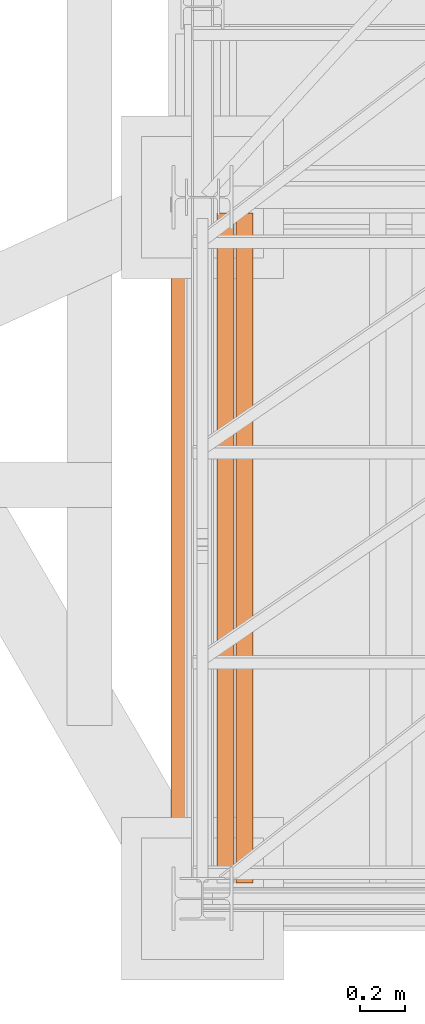
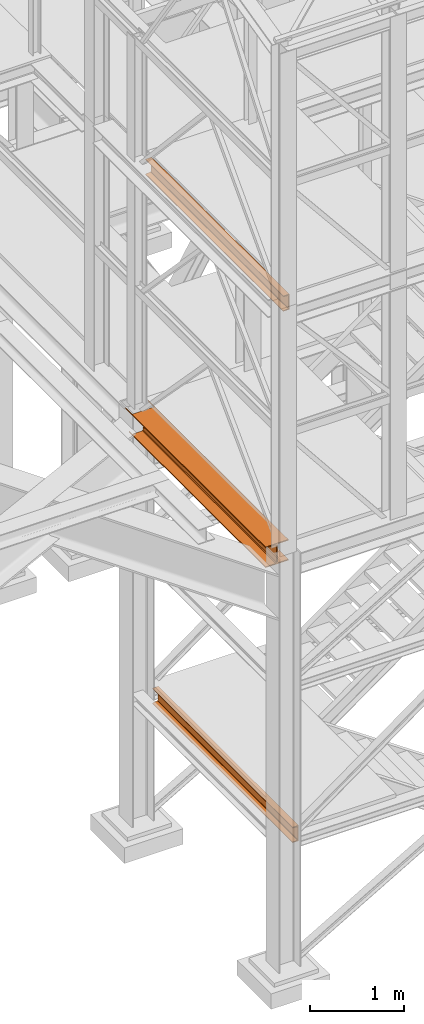
# One storey, part 5 of 208: 3 proxies.
"""IFC2X3 building model written with IfcOpenShell, lengths in millimetres."""

from ifc_helpers import new_model, entity, si_unit, converted_unit, frame, origin, origin_with_axes, place, context, subcontext, project, spatial, faceted_brep, element, save


model = new_model("IFC2X3")

# Units and contexts
model_context = context("Model", 3, precision=1e-05, world=origin())
plan_context = context("Plan", 3, precision=1e-05, world=origin())
body_context = subcontext(model_context, "Body", "Model", "MODEL_VIEW")
ifc_project = project(units=[si_unit("LENGTHUNIT", "METRE", prefix="MILLI"), converted_unit("PLANEANGLEUNIT", "DEGREE", entity("IfcPlaneAngleMeasure", 0.0174532925199433), si_unit("PLANEANGLEUNIT", "RADIAN"), dimensions=[0, 0, 0, 0, 0, 0, 0]), si_unit("AREAUNIT", "SQUARE_METRE"), si_unit("VOLUMEUNIT", "CUBIC_METRE")], contexts=[model_context, plan_context])

# Building, storey
building_placement = place(None, origin())
building = spatial("IfcBuilding", under=ifc_project, at=building_placement, CompositionType="COMPLEX")
storey_placement = place(building_placement, origin_with_axes())
storey = spatial("IfcBuildingStorey", under=building, at=storey_placement, Name="Geschoss", CompositionType="ELEMENT")

# Proxies
proxy_1_placement = place(storey_placement, frame((1058.254967932617, -25032.57438972183, 5014.98999463558), z_axis=(0.0, 0.0, 1.0), x_axis=(1.0, 0.0, 0.0)))
element("IfcBuildingElementProxy", 1, at=proxy_1_placement, inside=storey, context=body_context, shape_type="Brep", body=[
    faceted_brep([(280.0100011920947, 2970.009999403952, 270.0100107288363), (274.9198562138097, 2970.009999403952, 270.0100107288363), (274.9198562138097, 2970.009999403952, 257.0100141859057), (280.0100011920947, 2970.009999403952, 257.0100141859057), (274.9198562138097, 2970.009999403952, 13.00999654293082), (274.9198562138097, 2970.009999403952, 0.01000000000021828), (280.0100011920947, 2970.009999403952, 0.01000000000021828), (280.0100011920947, 2970.009999403952, 13.00999654293082), (4.91984548497453, 2970.009999403952, 257.0100141859057), (4.91984548497453, 2970.009999403952, 270.0100107288363), (0.009999999999990905, 2970.009999403952, 270.0100107288363), (0.009999999999990905, 2970.009999403952, 257.0100141859057), (0.009999999999990905, 2970.009999403952, 270.0100107288363), (4.91984548497453, 2970.009999403952, 270.0100107288363), (4.91984548497453, 2830.009998807902, 270.0100107288354), (274.9198562138097, 2830.009998807902, 270.0100107288354), (274.9198562138097, 2970.009999403952, 270.0100107288363), (280.0100011920947, 2970.009999403952, 270.0100107288363), (280.0100011920947, 0.00999999999839929, 270.0100107288354), (0.009999999999990905, 0.00999999999839929, 270.0100107288354), (0.009999999999990905, 2970.009999403952, 257.0100141859057), (0.009999999999990905, 2970.009999403952, 270.0100107288363), (0.009999999999990905, 0.00999999999839929, 270.0100107288354), (0.009999999999990905, 0.00999999999839929, 257.0100141859057), (4.91984548497453, 2970.009999403952, 257.0100141859057), (0.009999999999990905, 2970.009999403952, 257.0100141859057), (0.009999999999990905, 0.00999999999839929, 257.0100141859057), (112.0099997317782, 0.00999999999839929, 257.0100141859057), (112.0099997317791, 2830.009998807902, 257.0100141859057), (4.91984548497453, 2830.009998807902, 257.0100141859057), (112.0099997317791, 2830.009998807902, 257.0100141859057), (112.0099997317782, 0.00999999999839929, 257.0100141859057), (124.4310805743924, 0.00999999999839929, 254.5239491558077), (124.4310805743933, 2830.009998807902, 254.5239491558077), (124.4310805743933, 2830.009998807902, 254.5239491558077), (124.4310805743924, 0.00999999999839929, 254.5239491558077), (133.5239363072813, 0.00999999999839929, 245.4310892319681), (133.5239363072803, 2830.009998807902, 245.4310892319681), (133.5239363072803, 2830.009998807902, 245.4310892319681), (133.5239363072813, 0.00999999999839929, 245.4310892319681), (136.0100004060566, 0.00999999999839929, 233.0100102519991), (136.0100004060566, 2830.009998807902, 233.0100102519991), (136.0100004060566, 2830.009998807902, 233.0100102519991), (136.0100004060566, 0.00999999999839929, 233.0100102519991), (136.0100004060566, 0.00999999999839929, 37.01000047683738), (136.0100004060566, 2830.009998807902, 37.01000047683738), (136.0100004060566, 2830.009998807902, 55.01001072883628), (136.0100004060557, 2803.43875191277, 55.01001072883719), (136.0100004060566, 2803.43875191277, 80.01001072883628), (136.0100004060557, 2830.009998807902, 80.01001072883628), (136.0100004060566, 2830.009998807902, 37.01000047683738), (136.0100004060566, 0.00999999999839929, 37.01000047683738), (133.5239363072813, 0.00999999999839929, 24.58892149686835), (133.5239363072813, 2830.009998807902, 24.58892149686835), (133.5239363072813, 2830.009998807902, 24.58892149686835), (133.5239363072813, 0.00999999999839929, 24.58892149686835), (124.4310805743924, 0.00999999999839929, 15.49606157302878), (124.4310805743924, 2830.009998807902, 15.49606157302878), (124.4310805743924, 2830.009998807902, 15.49606157302878), (124.4310805743924, 0.00999999999839929, 15.49606157302878), (112.0099997317791, 0.00999999999839929, 13.00999654293082), (112.0099997317791, 2830.009998807902, 13.00999654293082), (4.91984548497453, 2830.009998807902, 13.00999654293173), (112.0099997317791, 2830.009998807902, 13.00999654293082), (112.0099997317791, 0.00999999999839929, 13.00999654293082), (0.009999999999990905, 0.00999999999839929, 13.00999654293082), (0.009999999999990905, 2890.498682317633, 13.00999654293082), (4.919845484972711, 2893.34256245166, 13.00999654293082), (0.009999999999990905, 2890.498682317633, 0.01000000000021828), (0.009999999999990905, 2890.498682317633, 13.00999654293082), (0.009999999999990905, 0.00999999999839929, 13.00999654293082), (0.009999999999990905, 0.00999999999839929, 0.01000000000021828), (280.0100011920947, 2970.009999403952, 0.01000000000021828), (274.9198562138097, 2970.009999403952, 0.01000000000021828), (274.9198562138106, 2830.009998807902, 0.01000000000112777), (4.91984548497453, 2830.009998807902, 0.01000000000112777), (4.919845484973621, 2893.342562451664, 0.01000000000021828), (0.009999999999990905, 2890.498682317633, 0.01000000000021828), (0.009999999999990905, 0.00999999999839929, 0.01000000000021828), (280.0100011920956, 0.00999999999839929, 0.01000000000021828), (280.0100011920947, 2970.009999403952, 13.00999654293082), (280.0100011920947, 2970.009999403952, 0.01000000000021828), (280.0100011920956, 0.00999999999839929, 0.01000000000021828), (280.0100011920938, 0.00999999999839929, 13.00999654293082), (274.9198562138097, 2970.009999403952, 13.00999654293082), (280.0100011920947, 2970.009999403952, 13.00999654293082), (280.0100011920938, 0.00999999999839929, 13.00999654293082), (168.0100014603138, 0.00999999999839929, 13.00999654293082), (168.0100014603138, 2830.009998807902, 13.00999654293082), (274.9198562138097, 2830.009998807902, 13.00999654293082), (168.0100014603138, 2830.009998807902, 13.00999654293082), (168.0100014603138, 0.00999999999839929, 13.00999654293082), (155.5889206176987, 0.00999999999839929, 15.49606157302878), (155.5889206176996, 2830.009998807902, 15.49606157302878), (155.5889206176996, 2830.009998807902, 15.49606157302878), (155.5889206176987, 0.00999999999839929, 15.49606157302878), (146.4960648848116, 0.00999999999839929, 24.58892149686835), (146.4960648848116, 2830.009998807902, 24.58892149686835), (146.4960648848116, 2830.009998807902, 24.58892149686835), (146.4960648848116, 0.00999999999839929, 24.58892149686835), (144.0100007860362, 0.00999999999839929, 37.01000047683647), (144.0100007860362, 2830.009998807902, 37.01000047683738), (144.0100007860362, 2830.009998807902, 37.01000047683738), (144.0100007860362, 0.00999999999839929, 37.01000047683647), (144.0100007860372, 0.00999999999839929, 233.0100102519964), (144.0100007860362, 2830.009998807902, 233.0100102519991), (144.0100007860362, 2830.009998807902, 80.01001072883628), (144.0100007860362, 2808.072511207734, 80.01001072883628), (144.0100007860362, 2808.072511207734, 55.01001072883628), (144.0100007860372, 2830.009998807902, 55.01001072883628), (144.0100007860362, 2830.009998807902, 233.0100102519991), (144.0100007860372, 0.00999999999839929, 233.0100102519964), (146.4960648848107, 0.00999999999839929, 245.4310892319663), (146.4960648848116, 2830.009998807902, 245.4310892319681), (146.4960648848116, 2830.009998807902, 245.4310892319681), (146.4960648848107, 0.00999999999839929, 245.4310892319663), (155.5889206176987, 0.00999999999839929, 254.5239491558068), (155.5889206176996, 2830.009998807902, 254.5239491558077), (155.5889206176996, 2830.009998807902, 254.5239491558077), (155.5889206176987, 0.00999999999839929, 254.5239491558068), (168.0100014603138, 0.00999999999839929, 257.0100141859057), (168.0100014603138, 2830.009998807902, 257.0100141859057), (280.0100011920947, 2970.009999403952, 257.0100141859057), (274.9198562138097, 2970.009999403952, 257.0100141859057), (274.9198562138097, 2830.009998807902, 257.0100141859066), (168.0100014603138, 2830.009998807902, 257.0100141859057), (168.0100014603138, 0.00999999999839929, 257.0100141859057), (280.0100011920938, 0.00999999999839929, 257.0100141859057), (280.0100011920947, 2970.009999403952, 270.0100107288363), (280.0100011920947, 2970.009999403952, 257.0100141859057), (280.0100011920938, 0.00999999999839929, 257.0100141859057), (280.0100011920947, 0.00999999999839929, 270.0100107288354), (280.0100011920947, 0.00999999999839929, 270.0100107288354), (280.0100011920938, 0.00999999999839929, 257.0100141859057), (168.0100014603138, 0.00999999999839929, 257.0100141859057), (155.5889206176987, 0.00999999999839929, 254.5239491558068), (146.4960648848107, 0.00999999999839929, 245.4310892319663), (144.0100007860372, 0.00999999999839929, 233.0100102519964), (144.0100007860362, 0.00999999999839929, 37.01000047683647), (146.4960648848116, 0.00999999999839929, 24.58892149686835), (155.5889206176987, 0.00999999999839929, 15.49606157302878), (168.0100014603138, 0.00999999999839929, 13.00999654293082), (280.0100011920938, 0.00999999999839929, 13.00999654293082), (280.0100011920956, 0.00999999999839929, 0.01000000000021828), (0.009999999999990905, 0.00999999999839929, 0.01000000000021828), (0.009999999999990905, 0.00999999999839929, 13.00999654293082), (112.0099997317791, 0.00999999999839929, 13.00999654293082), (124.4310805743924, 0.00999999999839929, 15.49606157302878), (133.5239363072813, 0.00999999999839929, 24.58892149686835), (136.0100004060566, 0.00999999999839929, 37.01000047683738), (136.0100004060566, 0.00999999999839929, 233.0100102519991), (133.5239363072813, 0.00999999999839929, 245.4310892319681), (124.4310805743924, 0.00999999999839929, 254.5239491558077), (112.0099997317782, 0.00999999999839929, 257.0100141859057), (0.009999999999990905, 0.00999999999839929, 257.0100141859057), (0.009999999999990905, 0.00999999999839929, 270.0100107288354), (136.0100004060566, 2803.43875191277, 80.01001072883628), (136.0100004060557, 2803.43875191277, 55.01001072883719), (144.0100007860362, 2808.072511207734, 55.01001072883628), (144.0100007860362, 2808.072511207734, 80.01001072883628), (136.0100004060557, 2803.43875191277, 55.01001072883719), (136.0100004060566, 2830.009998807902, 55.01001072883628), (144.0100007860372, 2830.009998807902, 55.01001072883628), (144.0100007860362, 2808.072511207734, 55.01001072883628), (4.919845484972711, 2893.34256245166, 13.00999654293082), (0.009999999999990905, 2890.498682317633, 13.00999654293082), (0.009999999999990905, 2890.498682317633, 0.01000000000021828), (4.919845484973621, 2893.342562451664, 0.01000000000021828), (136.0100004060557, 2830.009998807902, 80.01001072883628), (136.0100004060566, 2803.43875191277, 80.01001072883628), (144.0100007860362, 2808.072511207734, 80.01001072883628), (144.0100007860362, 2830.009998807902, 80.01001072883628), (4.91984548497453, 2830.009998807902, 257.0100141859057), (112.0099997317791, 2830.009998807902, 257.0100141859057), (124.4310805743933, 2830.009998807902, 254.5239491558077), (133.5239363072803, 2830.009998807902, 245.4310892319681), (136.0100004060566, 2830.009998807902, 233.0100102519991), (136.0100004060557, 2830.009998807902, 80.01001072883628), (144.0100007860362, 2830.009998807902, 80.01001072883628), (144.0100007860362, 2830.009998807902, 233.0100102519991), (146.4960648848116, 2830.009998807902, 245.4310892319681), (155.5889206176996, 2830.009998807902, 254.5239491558077), (168.0100014603138, 2830.009998807902, 257.0100141859057), (274.9198562138097, 2830.009998807902, 257.0100141859066), (274.9198562138097, 2830.009998807902, 270.0100107288354), (4.91984548497453, 2830.009998807902, 270.0100107288354), (4.91984548497453, 2830.009998807902, 0.01000000000112777), (274.9198562138106, 2830.009998807902, 0.01000000000112777), (274.9198562138097, 2830.009998807902, 13.00999654293082), (168.0100014603138, 2830.009998807902, 13.00999654293082), (155.5889206176996, 2830.009998807902, 15.49606157302878), (146.4960648848116, 2830.009998807902, 24.58892149686835), (144.0100007860362, 2830.009998807902, 37.01000047683738), (144.0100007860372, 2830.009998807902, 55.01001072883628), (136.0100004060566, 2830.009998807902, 55.01001072883628), (136.0100004060566, 2830.009998807902, 37.01000047683738), (133.5239363072813, 2830.009998807902, 24.58892149686835), (124.4310805743924, 2830.009998807902, 15.49606157302878), (112.0099997317791, 2830.009998807902, 13.00999654293082), (4.91984548497453, 2830.009998807902, 13.00999654293173), (274.9198562138097, 2830.009998807902, 257.0100141859066), (274.9198562138097, 2970.009999403952, 257.0100141859057), (274.9198562138097, 2970.009999403952, 270.0100107288363), (274.9198562138097, 2830.009998807902, 270.0100107288354), (274.9198562138106, 2830.009998807902, 0.01000000000112777), (274.9198562138097, 2970.009999403952, 0.01000000000021828), (274.9198562138097, 2970.009999403952, 13.00999654293082), (274.9198562138097, 2830.009998807902, 13.00999654293082), (4.91984548497453, 2830.009998807902, 270.0100107288354), (4.91984548497453, 2970.009999403952, 270.0100107288363), (4.91984548497453, 2970.009999403952, 257.0100141859057), (4.91984548497453, 2830.009998807902, 257.0100141859057), (4.91984548497453, 2830.009998807902, 13.00999654293173), (4.919845484972711, 2893.34256245166, 13.00999654293082), (4.919845484973621, 2893.342562451664, 0.01000000000021828), (4.91984548497453, 2830.009998807902, 0.01000000000112777)], [[[0, 1, 2, 3]], [[4, 5, 6, 7]], [[8, 9, 10, 11]], [[12, 13, 14, 15, 16, 17, 18, 19]], [[20, 21, 22, 23]], [[24, 25, 26, 27, 28, 29]], [[30, 31, 32, 33]], [[34, 35, 36, 37]], [[38, 39, 40, 41]], [[42, 43, 44, 45, 46, 47, 48, 49]], [[50, 51, 52, 53]], [[54, 55, 56, 57]], [[58, 59, 60, 61]], [[62, 63, 64, 65, 66, 67]], [[68, 69, 70, 71]], [[72, 73, 74, 75, 76, 77, 78, 79]], [[80, 81, 82, 83]], [[84, 85, 86, 87, 88, 89]], [[90, 91, 92, 93]], [[94, 95, 96, 97]], [[98, 99, 100, 101]], [[102, 103, 104, 105, 106, 107, 108, 109]], [[110, 111, 112, 113]], [[114, 115, 116, 117]], [[118, 119, 120, 121]], [[122, 123, 124, 125, 126, 127]], [[128, 129, 130, 131]], [[132, 133, 134, 135, 136, 137, 138, 139, 140, 141, 142, 143, 144, 145, 146, 147, 148, 149, 150, 151, 152, 153, 154, 155]], [[156, 157, 158, 159]], [[160, 161, 162, 163]], [[164, 165, 166, 167]], [[168, 169, 170, 171]], [[172, 173, 174, 175, 176, 177, 178, 179, 180, 181, 182, 183, 184, 185]], [[186, 187, 188, 189, 190, 191, 192, 193, 194, 195, 196, 197, 198, 199]], [[200, 201, 202, 203]], [[204, 205, 206, 207]], [[208, 209, 210, 211]], [[212, 213, 214, 215]]], orient=[[False], [False], [False], [False], [False], [False], [False], [False], [False], [False], [False], [False], [False], [False], [False], [False], [False], [False], [False], [False], [False], [False], [False], [False], [False], [False], [False], [False], [False], [False], [False], [False], [False], [False], [False], [False], [False], [False]]),
])
proxy_2_placement = place(storey_placement, frame((1347.770835871715, -25102.57439001986, 1399.989998075481), z_axis=(0.0, 0.0, 1.0), x_axis=(1.0, 0.0, 0.0)))
element("IfcBuildingElementProxy", 2, at=proxy_2_placement, inside=storey, context=body_context, shape_type="Brep", body=[
    faceted_brep([(75.01000111758708, 2970.009999403952, 200.0100029802322), (0.009999999999990905, 2970.009999403952, 200.0100029802322), (0.009999999999990905, 2970.009999403952, 197.0491720533371), (1.12600011587142, 2970.009999403952, 192.6511688327789), (5.53152842283248, 2970.009999403952, 191.0682780838013), (55.92706931591033, 2970.009999403952, 187.036634812355), (61.66620032697915, 2970.009999403952, 185.4414133524895), (65.51985109061002, 2970.009999403952, 181.1611144042015), (66.51000065565108, 2970.009999403952, 175.5732609128952), (66.51000065565108, 2970.009999403952, 24.44674206733703), (65.51985109061002, 2970.009999403952, 18.85888857603072), (61.66620032697915, 2970.009999403952, 14.57858962774276), (55.92706931591033, 2970.009999403952, 12.98336816787719), (5.53152842283248, 2970.009999403952, 8.95172489643096), (1.12600011587142, 2970.009999403952, 7.368834147453299), (0.009999999999990905, 2970.009999403952, 2.970830926895133), (0.009999999999990905, 2970.009999403952, 0.009999999999990905), (75.01000111758708, 2970.009999403952, 0.009999999999990905), (75.01000111758708, 2970.009999403952, 0.009999999999990905), (75.01000111758708, 0.01000000000203727, 0.009999999999990905), (75.01000111758708, 0.01000000000203727, 200.0100029802322), (75.01000111758708, 2970.009999403952, 200.0100029802322), (0.009999999999990905, 2970.009999403952, 0.009999999999990905), (0.009999999999990905, 0.01000000000203727, 0.009999999999990905), (75.01000111758708, 0.01000000000203727, 0.009999999999990905), (75.01000111758708, 2970.009999403952, 0.009999999999990905), (0.009999999999990905, 2970.009999403952, 2.970830926895133), (0.009999999999990905, 0.01000000000203727, 2.970830926895133), (0.009999999999990905, 0.01000000000203727, 0.009999999999990905), (0.009999999999990905, 2970.009999403952, 0.009999999999990905), (1.12600011587142, 2970.009999403952, 7.368834147453299), (1.12600011587142, 0.01000000000203727, 7.368834147453299), (0.009999999999990905, 0.01000000000203727, 2.970830926895133), (0.009999999999990905, 2970.009999403952, 2.970830926895133), (5.53152842283248, 2970.009999403952, 8.95172489643096), (5.53152842283248, 0.01000000000203727, 8.95172489643096), (1.12600011587142, 0.01000000000203727, 7.368834147453299), (1.12600011587142, 2970.009999403952, 7.368834147453299), (55.92706931591033, 2970.009999403952, 12.98336816787719), (55.92706931591033, 0.01000000000203727, 12.98336816787719), (5.53152842283248, 0.01000000000203727, 8.95172489643096), (5.53152842283248, 2970.009999403952, 8.95172489643096), (61.66620032697915, 2970.009999403952, 14.57858962774276), (61.66620032697915, 0.01000000000203727, 14.57858962774276), (55.92706931591033, 0.01000000000203727, 12.98336816787719), (55.92706931591033, 2970.009999403952, 12.98336816787719), (65.51985109061002, 2970.009999403952, 18.85888857603072), (65.51985109061002, 0.01000000000203727, 18.85888857603072), (61.66620032697915, 0.01000000000203727, 14.57858962774276), (61.66620032697915, 2970.009999403952, 14.57858962774276), (66.51000065565108, 2970.009999403952, 24.44674206733703), (66.51000065565108, 0.01000000000203727, 24.44674206733703), (65.51985109061002, 0.01000000000203727, 18.85888857603072), (65.51985109061002, 2970.009999403952, 18.85888857603072), (66.51000065565108, 2970.009999403952, 175.5732609128952), (66.51000065565108, 0.01000000000203727, 175.5732609128952), (66.51000065565108, 0.01000000000203727, 24.44674206733703), (66.51000065565108, 2970.009999403952, 24.44674206733703), (65.51985109061002, 2970.009999403952, 181.1611144042015), (65.51985109061002, 0.01000000000203727, 181.1611144042015), (66.51000065565108, 0.01000000000203727, 175.5732609128952), (66.51000065565108, 2970.009999403952, 175.5732609128952), (61.66620032697915, 2970.009999403952, 185.4414133524895), (61.66620032697915, 0.01000000000203727, 185.4414133524895), (65.51985109061002, 0.01000000000203727, 181.1611144042015), (65.51985109061002, 2970.009999403952, 181.1611144042015), (55.92706931591033, 2970.009999403952, 187.036634812355), (55.92706931591033, 0.01000000000203727, 187.036634812355), (61.66620032697915, 0.01000000000203727, 185.4414133524895), (61.66620032697915, 2970.009999403952, 185.4414133524895), (5.53152842283248, 2970.009999403952, 191.0682780838013), (5.53152842283248, 0.01000000000203727, 191.0682780838013), (55.92706931591033, 0.01000000000203727, 187.036634812355), (55.92706931591033, 2970.009999403952, 187.036634812355), (1.12600011587142, 2970.009999403952, 192.6511688327789), (1.12600011587142, 0.01000000000203727, 192.6511688327789), (5.53152842283248, 0.01000000000203727, 191.0682780838013), (5.53152842283248, 2970.009999403952, 191.0682780838013), (0.009999999999990905, 2970.009999403952, 197.0491720533371), (0.009999999999990905, 0.01000000000203727, 197.0491720533371), (1.12600011587142, 0.01000000000203727, 192.6511688327789), (1.12600011587142, 2970.009999403952, 192.6511688327789), (0.009999999999990905, 2970.009999403952, 200.0100029802322), (0.009999999999990905, 0.01000000000203727, 200.0100029802322), (0.009999999999990905, 0.01000000000203727, 197.0491720533371), (0.009999999999990905, 2970.009999403952, 197.0491720533371), (75.01000111758708, 2970.009999403952, 200.0100029802322), (75.01000111758708, 0.01000000000203727, 200.0100029802322), (0.009999999999990905, 0.01000000000203727, 200.0100029802322), (0.009999999999990905, 2970.009999403952, 200.0100029802322), (75.01000111758708, 0.01000000000203727, 200.0100029802322), (75.01000111758708, 0.01000000000203727, 0.009999999999990905), (0.009999999999990905, 0.01000000000203727, 0.009999999999990905), (0.009999999999990905, 0.01000000000203727, 2.970830926895133), (1.12600011587142, 0.01000000000203727, 7.368834147453299), (5.53152842283248, 0.01000000000203727, 8.95172489643096), (55.92706931591033, 0.01000000000203727, 12.98336816787719), (61.66620032697915, 0.01000000000203727, 14.57858962774276), (65.51985109061002, 0.01000000000203727, 18.85888857603072), (66.51000065565108, 0.01000000000203727, 24.44674206733703), (66.51000065565108, 0.01000000000203727, 175.5732609128952), (65.51985109061002, 0.01000000000203727, 181.1611144042015), (61.66620032697915, 0.01000000000203727, 185.4414133524895), (55.92706931591033, 0.01000000000203727, 187.036634812355), (5.53152842283248, 0.01000000000203727, 191.0682780838013), (1.12600011587142, 0.01000000000203727, 192.6511688327789), (0.009999999999990905, 0.01000000000203727, 197.0491720533371), (0.009999999999990905, 0.01000000000203727, 200.0100029802322)], [[[0, 1, 2, 3, 4, 5, 6, 7, 8, 9, 10, 11, 12, 13, 14, 15, 16, 17]], [[18, 19, 20, 21]], [[22, 23, 24, 25]], [[26, 27, 28, 29]], [[30, 31, 32, 33]], [[34, 35, 36, 37]], [[38, 39, 40, 41]], [[42, 43, 44, 45]], [[46, 47, 48, 49]], [[50, 51, 52, 53]], [[54, 55, 56, 57]], [[58, 59, 60, 61]], [[62, 63, 64, 65]], [[66, 67, 68, 69]], [[70, 71, 72, 73]], [[74, 75, 76, 77]], [[78, 79, 80, 81]], [[82, 83, 84, 85]], [[86, 87, 88, 89]], [[90, 91, 92, 93, 94, 95, 96, 97, 98, 99, 100, 101, 102, 103, 104, 105, 106, 107]]], orient=[[False], [False], [False], [False], [False], [False], [False], [False], [False], [False], [False], [False], [False], [False], [False], [False], [False], [False], [False], [False]]),
])
proxy_3_placement = place(storey_placement, frame((1263.401408260116, -25052.57438554951, 8269.989998509878), z_axis=(0.0, 0.0, 1.0), x_axis=(1.0, 0.0, 0.0)))
element("IfcBuildingElementProxy", 3, at=proxy_3_placement, inside=storey, context=body_context, shape_type="Brep", body=[
    faceted_brep([(75.01000111758708, 2920.009994933604, 200.0100029802325), (0.009999999999990905, 2920.009994933604, 200.0100029802325), (0.009999999999990905, 2920.009994933604, 197.0491720533373), (1.12600011587142, 2920.009994933604, 192.6511688327792), (5.53152842283248, 2920.009994933604, 191.0682780838015), (55.92706931591033, 2920.009994933604, 187.0366348123553), (61.66620032697915, 2920.009994933604, 185.4414133524897), (65.51985109061002, 2920.009994933604, 181.1611144042017), (66.51000065565108, 2920.009994933604, 175.5732609128954), (66.51000065565108, 2920.009994933604, 24.44674206733725), (65.51985109061002, 2920.009994933604, 18.85888857603095), (61.66620032697915, 2920.009994933604, 14.57858962774299), (55.92706931591033, 2920.009994933604, 12.98336816787742), (5.53152842283248, 2920.009994933604, 8.951724896431188), (1.12600011587142, 2920.009994933604, 7.368834147453526), (0.009999999999990905, 2920.009994933604, 2.97083092689536), (0.009999999999990905, 2920.009994933604, 0.01000000000021828), (75.01000111758708, 2920.009994933604, 0.01000000000021828), (75.01000111758708, 2920.009994933604, 0.01000000000021828), (75.01000111758708, 0.00999999999839929, 0.01000000000021828), (75.01000111758708, 0.00999999999839929, 200.0100029802325), (75.01000111758708, 2920.009994933604, 200.0100029802325), (0.009999999999990905, 2920.009994933604, 0.01000000000021828), (0.009999999999990905, 0.00999999999839929, 0.01000000000021828), (75.01000111758708, 0.00999999999839929, 0.01000000000021828), (75.01000111758708, 2920.009994933604, 0.01000000000021828), (0.009999999999990905, 2920.009994933604, 2.97083092689536), (0.009999999999990905, 0.00999999999839929, 2.97083092689536), (0.009999999999990905, 0.00999999999839929, 0.01000000000021828), (0.009999999999990905, 2920.009994933604, 0.01000000000021828), (1.12600011587142, 2920.009994933604, 7.368834147453526), (1.12600011587142, 0.00999999999839929, 7.368834147453526), (0.009999999999990905, 0.00999999999839929, 2.97083092689536), (0.009999999999990905, 2920.009994933604, 2.97083092689536), (5.53152842283248, 2920.009994933604, 8.951724896431188), (5.53152842283248, 0.00999999999839929, 8.951724896431188), (1.12600011587142, 0.00999999999839929, 7.368834147453526), (1.12600011587142, 2920.009994933604, 7.368834147453526), (55.92706931591033, 2920.009994933604, 12.98336816787742), (55.92706931591033, 0.00999999999839929, 12.98336816787742), (5.53152842283248, 0.00999999999839929, 8.951724896431188), (5.53152842283248, 2920.009994933604, 8.951724896431188), (61.66620032697915, 2920.009994933604, 14.57858962774299), (61.66620032697915, 0.00999999999839929, 14.57858962774299), (55.92706931591033, 0.00999999999839929, 12.98336816787742), (55.92706931591033, 2920.009994933604, 12.98336816787742), (65.51985109061002, 2920.009994933604, 18.85888857603095), (65.51985109061002, 0.00999999999839929, 18.85888857603095), (61.66620032697915, 0.00999999999839929, 14.57858962774299), (61.66620032697915, 2920.009994933604, 14.57858962774299), (66.51000065565108, 2920.009994933604, 24.44674206733725), (66.51000065565108, 0.00999999999839929, 24.44674206733725), (65.51985109061002, 0.00999999999839929, 18.85888857603095), (65.51985109061002, 2920.009994933604, 18.85888857603095), (66.51000065565108, 2920.009994933604, 175.5732609128954), (66.51000065565108, 0.00999999999839929, 175.5732609128954), (66.51000065565108, 0.00999999999839929, 24.44674206733725), (66.51000065565108, 2920.009994933604, 24.44674206733725), (65.51985109061002, 2920.009994933604, 181.1611144042017), (65.51985109061002, 0.00999999999839929, 181.1611144042017), (66.51000065565108, 0.00999999999839929, 175.5732609128954), (66.51000065565108, 2920.009994933604, 175.5732609128954), (61.66620032697915, 2920.009994933604, 185.4414133524897), (61.66620032697915, 0.00999999999839929, 185.4414133524897), (65.51985109061002, 0.00999999999839929, 181.1611144042017), (65.51985109061002, 2920.009994933604, 181.1611144042017), (55.92706931591033, 2920.009994933604, 187.0366348123553), (55.92706931591033, 0.00999999999839929, 187.0366348123553), (61.66620032697915, 0.00999999999839929, 185.4414133524897), (61.66620032697915, 2920.009994933604, 185.4414133524897), (5.53152842283248, 2920.009994933604, 191.0682780838015), (5.53152842283248, 0.00999999999839929, 191.0682780838015), (55.92706931591033, 0.00999999999839929, 187.0366348123553), (55.92706931591033, 2920.009994933604, 187.0366348123553), (1.12600011587142, 2920.009994933604, 192.6511688327792), (1.12600011587142, 0.00999999999839929, 192.6511688327792), (5.53152842283248, 0.00999999999839929, 191.0682780838015), (5.53152842283248, 2920.009994933604, 191.0682780838015), (0.009999999999990905, 2920.009994933604, 197.0491720533373), (0.009999999999990905, 0.00999999999839929, 197.0491720533373), (1.12600011587142, 0.00999999999839929, 192.6511688327792), (1.12600011587142, 2920.009994933604, 192.6511688327792), (0.009999999999990905, 2920.009994933604, 200.0100029802325), (0.009999999999990905, 0.00999999999839929, 200.0100029802325), (0.009999999999990905, 0.00999999999839929, 197.0491720533373), (0.009999999999990905, 2920.009994933604, 197.0491720533373), (75.01000111758708, 2920.009994933604, 200.0100029802325), (75.01000111758708, 0.00999999999839929, 200.0100029802325), (0.009999999999990905, 0.00999999999839929, 200.0100029802325), (0.009999999999990905, 2920.009994933604, 200.0100029802325), (75.01000111758708, 0.00999999999839929, 0.01000000000021828), (0.009999999999990905, 0.00999999999839929, 0.01000000000021828), (0.009999999999990905, 0.00999999999839929, 2.97083092689536), (1.12600011587142, 0.00999999999839929, 7.368834147453526), (5.53152842283248, 0.00999999999839929, 8.951724896431188), (55.92706931591033, 0.00999999999839929, 12.98336816787742), (61.66620032697915, 0.00999999999839929, 14.57858962774299), (65.51985109061002, 0.00999999999839929, 18.85888857603095), (66.51000065565108, 0.00999999999839929, 24.44674206733725), (66.51000065565108, 0.00999999999839929, 175.5732609128954), (65.51985109061002, 0.00999999999839929, 181.1611144042017), (61.66620032697915, 0.00999999999839929, 185.4414133524897), (55.92706931591033, 0.00999999999839929, 187.0366348123553), (5.53152842283248, 0.00999999999839929, 191.0682780838015), (1.12600011587142, 0.00999999999839929, 192.6511688327792), (0.009999999999990905, 0.00999999999839929, 197.0491720533373), (0.009999999999990905, 0.00999999999839929, 200.0100029802325), (75.01000111758708, 0.00999999999839929, 200.0100029802325)], [[[0, 1, 2, 3, 4, 5, 6, 7, 8, 9, 10, 11, 12, 13, 14, 15, 16, 17]], [[18, 19, 20, 21]], [[22, 23, 24, 25]], [[26, 27, 28, 29]], [[30, 31, 32, 33]], [[34, 35, 36, 37]], [[38, 39, 40, 41]], [[42, 43, 44, 45]], [[46, 47, 48, 49]], [[50, 51, 52, 53]], [[54, 55, 56, 57]], [[58, 59, 60, 61]], [[62, 63, 64, 65]], [[66, 67, 68, 69]], [[70, 71, 72, 73]], [[74, 75, 76, 77]], [[78, 79, 80, 81]], [[82, 83, 84, 85]], [[86, 87, 88, 89]], [[90, 91, 92, 93, 94, 95, 96, 97, 98, 99, 100, 101, 102, 103, 104, 105, 106, 107]]], orient=[[False], [False], [False], [False], [False], [False], [False], [False], [False], [False], [False], [False], [False], [False], [False], [False], [False], [False], [False], [False]]),
])

save(model, "model.ifc")
